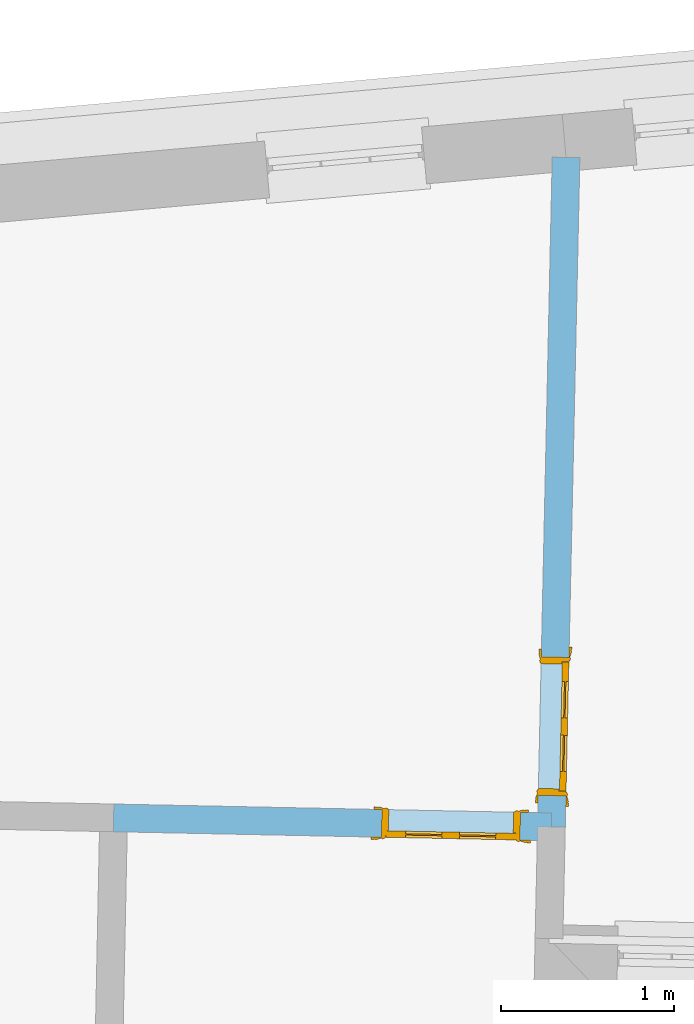
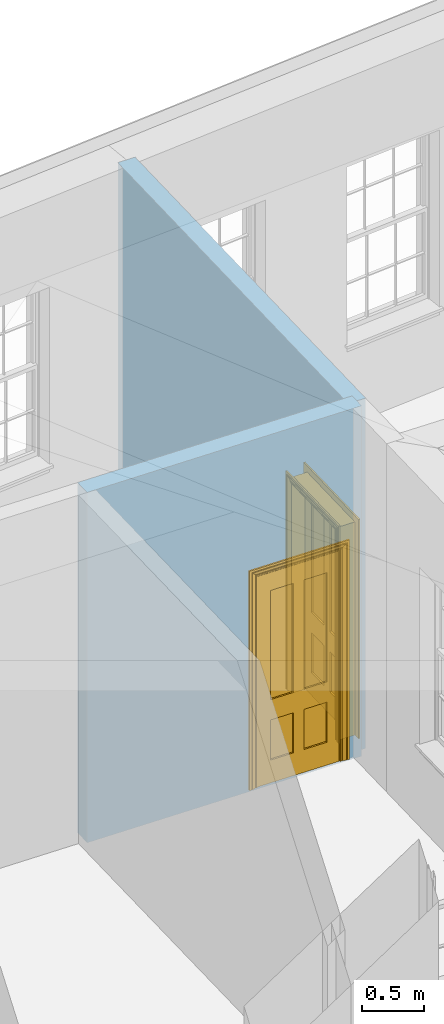
# One storey, part 10 of 14: 2 doors, 2 openings, plus 2 elements that do not belong to this part.
"""IFC2X3 building model written with IfcOpenShell, lengths in metres."""

import ifcopenshell
import ifcopenshell.guid

model = None  # the IFC model being written
_history = None  # IfcOwnerHistory: only IFC2X3 demands one
_inside = {}  # id of a spatial element -> (the spatial element, [elements in it])
_under = {}  # id of a project, library or spatial element -> (it, [spatial elements below it])
_declared = {}  # id of a project -> (the project, [libraries it declares])
_typed = {}  # id of a type object -> (the type object, [elements of that type])
_made_of = {}  # id of a material, layer set ... -> (it, [elements and type objects made of it])


def new_model(schema):
    """Start an empty IFC model of exactly this schema.

    Asked for "IFC4X3", IfcOpenShell would pick the latest addendum, in which some entities
    have other attributes; the version numbers below select the first issue.
    IFC2X3 requires an IfcOwnerHistory on every rooted entity: one is made here for all.
    """
    global model, _history
    if schema == "IFC4X3":
        model = ifcopenshell.file(schema_version=(4, 3, 0, 0))
    else:
        model = ifcopenshell.file(schema=schema)
    _inside.clear()
    _under.clear()
    _declared.clear()
    _typed.clear()
    _made_of.clear()
    _history = None
    if model.schema == "IFC2X3":
        org = make("IfcOrganization", Name="unknown")
        user = make(
            "IfcPersonAndOrganization",
            ThePerson=make("IfcPerson", FamilyName="unknown"),
            TheOrganization=org,
        )
        app = make(
            "IfcApplication",
            ApplicationDeveloper=org,
            Version="unknown",
            ApplicationFullName="unknown",
            ApplicationIdentifier="unknown",
        )
        _history = make(
            "IfcOwnerHistory",
            OwningUser=user,
            OwningApplication=app,
            ChangeAction="ADDED",
            CreationDate=0,
        )
    return model


def make(cls, **values):
    """One entity of the class cls with the attributes given. An attribute that is None is left unset."""
    return model.create_entity(
        cls, **{name: value for name, value in values.items() if value is not None}
    )


def rooted(cls, **values):
    """An entity with a GlobalId (a new one), such as an element, a storey or a relation."""
    return make(cls, GlobalId=ifcopenshell.guid.new(), OwnerHistory=_history, **values)


def si_unit(unit_type, name, prefix=None):
    """IfcSIUnit, for example si_unit("LENGTHUNIT", "METRE", prefix="MILLI")."""
    return make("IfcSIUnit", UnitType=unit_type, Prefix=prefix, Name=name)


def assignment(units):
    """IfcUnitAssignment: the units of a project."""
    return None if units is None else make("IfcUnitAssignment", Units=units)


def point(xyz):
    """IfcCartesianPoint."""
    return None if xyz is None else make("IfcCartesianPoint", Coordinates=xyz)


def direction(xyz):
    """IfcDirection."""
    return None if xyz is None else make("IfcDirection", DirectionRatios=xyz)


def frame(location, z_axis=None, x_axis=None):
    """IfcAxis2Placement3D, a coordinate frame: its origin and axes. An axis left out is left unset."""
    return make(
        "IfcAxis2Placement3D",
        Location=point(location),
        Axis=direction(z_axis),
        RefDirection=direction(x_axis),
    )


def origin():
    """The frame at (0, 0, 0) with its axes left unset."""
    return frame((0.0, 0.0, 0.0))


def place(relative_to, where):
    """IfcLocalPlacement: puts the frame where relative to a parent placement (None: the world)."""
    return make(
        "IfcLocalPlacement", PlacementRelTo=relative_to, RelativePlacement=where
    )


def context(
    kind, dimensions, precision=None, world=None, true_north=None, identifier=None
):
    """IfcGeometricRepresentationContext, for example the 3D "Model" context."""
    return make(
        "IfcGeometricRepresentationContext",
        ContextIdentifier=identifier,
        ContextType=kind,
        CoordinateSpaceDimension=dimensions,
        Precision=precision,
        WorldCoordinateSystem=world,
        TrueNorth=true_north,
    )


def subcontext(parent, identifier, kind, view, scale=None):
    """IfcGeometricRepresentationSubContext, for example "Body" below "Model"."""
    return make(
        "IfcGeometricRepresentationSubContext",
        ContextIdentifier=identifier,
        ContextType=kind,
        ParentContext=parent,
        TargetScale=scale,
        TargetView=view,
    )


def project(units=None, contexts=None):
    """IfcProject with its units and contexts."""
    return rooted(
        "IfcProject",
        Name="project",
        RepresentationContexts=contexts,
        UnitsInContext=assignment(units),
    )


def spatial(cls, under=None, at=None, **own):
    """A site, building, storey or space (cls), placed at a placement, below another one or the project."""
    s = rooted(cls, ObjectPlacement=at, **own)
    if under is not None:
        _under.setdefault(under.id(), (under, []))[1].append(s)
    return s


def polyline(points):
    """IfcPolyline through the points."""
    return make("IfcPolyline", Points=[point(p) for p in points])


def outline(outer, holes=None, kind="AREA"):
    """IfcArbitraryClosedProfileDef: a profile drawn as a closed curve; with holes, ...WithVoids."""
    if holes is None:
        return make("IfcArbitraryClosedProfileDef", ProfileType=kind, OuterCurve=outer)
    return make(
        "IfcArbitraryProfileDefWithVoids",
        ProfileType=kind,
        OuterCurve=outer,
        InnerCurves=holes,
    )


def extrude(swept, where, along, depth):
    """IfcExtrudedAreaSolid: the profile swept, set in the frame where, extruded along a direction by depth."""
    return make(
        "IfcExtrudedAreaSolid",
        SweptArea=swept,
        Position=where,
        ExtrudedDirection=direction(along),
        Depth=depth,
    )


def faces_of(points, faces, orient=None, outer=None):
    """IfcFace entities. A face is a list of loops; a loop is a list of indices into points, from 0.

    orient and outer hold one flag for each loop. By default every Orientation is true, the
    first loop of a face is its IfcFaceOuterBound and the others are IfcFaceBound.
    """
    made = []
    for i, loops in enumerate(faces):
        bounds = []
        for j, loop in enumerate(loops):
            is_outer = j == 0 if outer is None else outer[i][j]
            bounds.append(
                make(
                    "IfcFaceOuterBound" if is_outer else "IfcFaceBound",
                    Bound=make("IfcPolyLoop", Polygon=[points[k] for k in loop]),
                    Orientation=True if orient is None else orient[i][j],
                )
            )
        made.append(make("IfcFace", Bounds=bounds))
    return made


def faceted_brep(points, faces, orient=None, outer=None, voids=None):
    """IfcFacetedBrep: a solid bounded by flat faces; with voids (closed shells), ...WithVoids."""
    shared = [point(p) for p in points]
    hull = make("IfcClosedShell", CfsFaces=faces_of(shared, faces, orient, outer))
    if voids is None:
        return make("IfcFacetedBrep", Outer=hull)
    return make(
        "IfcFacetedBrepWithVoids",
        Outer=hull,
        Voids=[
            make(cls, CfsFaces=faces_of(shared, fs, o, b)) for cls, fs, o, b in voids
        ],
    )


def shape(context_of_items, identifier, shape_type, items):
    """IfcShapeRepresentation: the items that make up one representation, for example the "Body"."""
    return make(
        "IfcShapeRepresentation",
        ContextOfItems=context_of_items,
        RepresentationIdentifier=identifier,
        RepresentationType=shape_type,
        Items=items,
    )


def material(Name=None, Category=None):
    """IfcMaterial."""
    return make("IfcMaterial", Name=Name, Category=Category)


def layer(
    of_material, thickness, ventilated=None, Name=None, Category=None, Priority=None
):
    """IfcMaterialLayer: one layer of a wall or slab, of a material (None: an air gap)."""
    return make(
        "IfcMaterialLayer",
        Material=of_material,
        LayerThickness=thickness,
        IsVentilated=ventilated,
        Name=Name,
        Category=Category,
        Priority=Priority,
    )


def layer_set(layers, Name=None):
    """IfcMaterialLayerSet."""
    return make("IfcMaterialLayerSet", MaterialLayers=layers, LayerSetName=Name)


def layer_usage(for_layer_set, set_direction, sense, offset, extent=None):
    """IfcMaterialLayerSetUsage: how a layer set lies in its element."""
    return make(
        "IfcMaterialLayerSetUsage",
        ForLayerSet=for_layer_set,
        LayerSetDirection=set_direction,
        DirectionSense=sense,
        OffsetFromReferenceLine=offset,
        ReferenceExtent=extent,
    )


def made_of(thing, what):
    """Note that an element or type object is made of a material, layer set ...; save() writes the relation."""
    if what is not None:
        _made_of.setdefault(what.id(), (what, []))[1].append(thing)
    return thing


def element(
    cls,
    number,
    at=None,
    inside=None,
    cuts=None,
    type_object=None,
    material=None,
    context=None,
    identifier="Body",
    shape_type=None,
    held_by="IfcProductDefinitionShape",
    body=None,
    shapes=None,
    **own,
):
    """One element of the class cls, such as IfcWall. Its Tag is "e" and its number.

    at: its placement. inside: the storey or other place that contains it. cuts: it is an
    opening in that element (IfcRelVoidsElement). A single representation is given by context,
    identifier, shape_type and body (its items); several are given by shapes. held_by: the class
    of the entity that holds the representations. save() writes the other relations.
    """
    e = rooted(cls, Tag="e%d" % number, ObjectPlacement=at, **own)
    if body is not None:
        shapes = [shape(context, identifier, shape_type, body)]
    if shapes is not None:
        e.Representation = make(held_by, Representations=shapes)
    if inside is not None:
        _inside.setdefault(inside.id(), (inside, []))[1].append(e)
    if cuts is not None:
        rooted(
            "IfcRelVoidsElement", RelatingBuildingElement=cuts, RelatedOpeningElement=e
        )
    if type_object is not None:
        _typed.setdefault(type_object.id(), (type_object, []))[1].append(e)
    return made_of(e, material)


def fill(opening, filler):
    """IfcRelFillsElement: the door or window that sits in an opening."""
    return rooted(
        "IfcRelFillsElement",
        RelatingOpeningElement=opening,
        RelatedBuildingElement=filler,
    )


def aggregate(whole, parts):
    """IfcRelAggregates: a whole, such as a stair, and the parts it consists of."""
    return rooted("IfcRelAggregates", RelatingObject=whole, RelatedObjects=parts)


def save(model, path):
    """Write the relations noted so far, then the file.

    IfcRelAggregates (storeys below a building ...), IfcRelContainedInSpatialStructure (elements
    in a storey), IfcRelDefinesByType, IfcRelAssociatesMaterial and IfcRelDeclares: one each for
    every whole, place, type object, material and project.
    """
    for whole, parts in _under.values():
        aggregate(whole, parts)
    for where, things in _inside.values():
        rooted(
            "IfcRelContainedInSpatialStructure",
            RelatedElements=things,
            RelatingStructure=where,
        )
    for kind, things in _typed.values():
        rooted("IfcRelDefinesByType", RelatedObjects=things, RelatingType=kind)
    for what, things in _made_of.values():
        rooted("IfcRelAssociatesMaterial", RelatedObjects=things, RelatingMaterial=what)
    for by, libraries in _declared.values():
        rooted("IfcRelDeclares", RelatingContext=by, RelatedDefinitions=libraries)
    model.write(path)


model = new_model("IFC2X3")

# Units and contexts
model_context = context("Model", 3, world=origin())
body_context = subcontext(model_context, "Body", "Model", "MODEL_VIEW")
ifc_project = project(units=[si_unit("PLANEANGLEUNIT", "RADIAN"), si_unit("MASSUNIT", "GRAM", prefix="KILO"), si_unit("FORCEUNIT", "NEWTON", prefix="KILO"), si_unit("LENGTHUNIT", "METRE")], contexts=[model_context])

# Site, building, storey
site_placement = place(None, origin())
site = spatial("IfcSite", under=ifc_project, at=site_placement, CompositionType="ELEMENT")
building_placement = place(None, origin())
building = spatial("IfcBuilding", under=site, at=building_placement, Name="Building plot-17", CompositionType="ELEMENT")
storey_placement = place(None, frame((0.0, 0.0, 6.15)))
storey = spatial("IfcBuildingStorey", under=building, at=storey_placement, Name="Floor 1", CompositionType="ELEMENT", Elevation=6.15)

# Wall, opening, door
ifc_material = material(Name="Masonry")
ifc_layer = layer(ifc_material, 0.16, ventilated=False)
ifc_layer_set = layer_set([ifc_layer], Name="My Wall")
ifc_layer_usage = layer_usage(ifc_layer_set, "AXIS2", "NEGATIVE", 0.08)
wall_1_placement = place(storey_placement, origin())
wall_1 = element("IfcWallStandardCase", 1, at=wall_1_placement, inside=storey, material=ifc_layer_usage, Name="interior", context=body_context, shape_type="SweptSolid", body=[
    extrude(outline(polyline([(82.5849794161083, 26.5932302615352), (82.4250176741949, 26.596728993307), (82.3405092270944, 22.7330094267186), (82.5004709690078, 22.7295106949468), (82.5849794161083, 26.5932302615352)])), origin(), (0.0, 0.0, 1.0), 3.45),
])
opening_1_placement = place(storey_placement, frame((0.0, 0.0, 0.0199999999999996)))
opening_1 = element("IfcOpeningElement", 2, at=opening_1_placement, cuts=wall_1, Name="Opening", ObjectType="Opening", context=body_context, shape_type="SweptSolid", body=[
    extrude(outline(polyline([(82.3619389591961, 23.7127750959385), (82.3444453003375, 22.9129663863712), (82.504407042251, 22.9094676545995), (82.5219007011096, 23.7092763641668), (82.3619389591961, 23.7127750959385)])), origin(), (0.0, 0.0, 1.0), 2.1),
])
door_1_placement = place(storey_placement, frame((82.4419198301528, 23.7110257300527, 0.0199999999999996), z_axis=(0.0, 0.0, 1.0), x_axis=(-0.0174936588585552, -0.799808709567319, 0.0)))
door_1 = element("IfcDoor", 3, at=door_1_placement, inside=storey, Name="bedroom inside door", OverallHeight=2.1, OverallWidth=0.8, context=body_context, shape_type="Brep", held_by="IfcProductRepresentation", body=[
    faceted_brep([(0.773, 0.08, 1.895), (0.66, 0.08, 1.895), (0.66, 0.08, 2.073), (0.773, 0.08, 2.073), (0.773, 0.08, 0.82), (0.66, 0.08, 0.82), (0.45, 0.08, 1.895), (0.45, 0.08, 2.073), (0.773, 0.08, 0.62), (0.66, 0.08, 0.62), (0.66, 0.065, 0.82), (0.66, 0.065, 1.895), (0.45, 0.065, 1.895), (0.35, 0.08, 1.895), (0.35, 0.08, 2.073), (0.773, 0.08, 0.225), (0.66, 0.08, 0.225), (0.45, 0.08, 0.62), (0.45, 0.08, 0.82), (0.45, 0.065, 0.82), (0.35, 0.08, 0.82), (0.14, 0.08, 2.073), (0.14, 0.08, 1.895), (0.773, 0.08, 0.0), (0.66, 0.08, 0.0), (0.66, 0.065, 0.225), (0.66, 0.065, 0.62), (0.45, 0.065, 0.62), (0.35, 0.08, 0.62), (0.35, 0.065, 0.82), (0.35, 0.065, 1.895), (0.14, 0.065, 1.895), (0.027, 0.08, 2.073), (0.027, 0.08, 1.895), (0.773, 0.042, 0.0), (0.66, 0.042, 0.0), (0.45, 0.08, 0.0), (0.45, 0.08, 0.225), (0.45, 0.065, 0.225), (0.35, 0.08, 0.225), (0.14, 0.08, 0.82), (0.14, 0.08, 0.62), (0.14, 0.065, 0.82), (0.027, 0.08, 0.82), (0.773, 0.042, 0.225), (0.66, 0.042, 0.225), (0.45, 0.042, 0.0), (0.35, 0.08, 0.0), (0.35, 0.065, 0.225), (0.35, 0.065, 0.62), (0.14, 0.065, 0.62), (0.027, 0.08, 0.62), (0.773, 0.042, 0.62), (0.66, 0.042, 0.62), (0.45, 0.042, 0.225), (0.35, 0.042, 0.0), (0.14, 0.08, 0.225), (0.14, 0.08, 0.0), (0.14, 0.065, 0.225), (0.027, 0.08, 0.225), (0.773, 0.042, 0.82), (0.66, 0.042, 0.82), (0.66, 0.057, 0.62), (0.66, 0.057, 0.225), (0.45, 0.057, 0.225), (0.35, 0.042, 0.225), (0.14, 0.042, 0.0), (0.027, 0.08, 0.0), (0.773, 0.042, 1.895), (0.66, 0.042, 1.895), (0.45, 0.042, 0.62), (0.45, 0.042, 0.82), (0.45, 0.057, 0.62), (0.35, 0.042, 0.62), (0.14, 0.042, 0.225), (0.027, 0.042, 0.0), (0.773, 0.042, 2.073), (0.66, 0.042, 2.073), (0.66, 0.057, 1.895), (0.66, 0.057, 0.82), (0.45, 0.057, 0.82), (0.35, 0.042, 0.82), (0.35, 0.057, 0.62), (0.35, 0.057, 0.225), (0.14, 0.057, 0.225), (0.027, 0.042, 0.225), (0.45, 0.042, 1.895), (0.45, 0.042, 2.073), (0.45, 0.057, 1.895), (0.35, 0.042, 1.895), (0.14, 0.042, 0.82), (0.14, 0.042, 0.62), (0.14, 0.057, 0.62), (0.027, 0.042, 0.62), (0.35, 0.042, 2.073), (0.35, 0.057, 1.895), (0.35, 0.057, 0.82), (0.14, 0.057, 0.82), (0.027, 0.042, 0.82), (0.14, 0.042, 2.073), (0.14, 0.042, 1.895), (0.14, 0.057, 1.895), (0.027, 0.042, 1.895), (0.027, 0.042, 2.073), (0.02, 0.085, 0.0), (0.005, 0.09, 0.0), (0.005, 0.09, 2.095), (0.02, 0.085, 2.08), (0.02, 0.08, 0.0), (0.0, 0.085, 0.0), (0.0, 0.085, 2.1), (0.795, 0.09, 2.095), (0.78, 0.085, 2.08), (0.02, 0.08, 2.08), (0.0, 0.08, 0.0), (-0.032, 0.095, 0.0), (-0.032, 0.095, 2.132), (0.8, 0.085, 2.1), (0.795, 0.09, 0.0), (0.78, 0.085, 0.0), (0.78, 0.08, 2.08), (0.04, 0.04, 0.0), (0.025, 0.04, 0.0), (0.025, 0.04, 2.075), (0.04, 0.04, 2.06), (-0.04, 0.09, 0.0), (-0.04, 0.09, 2.14), (0.832, 0.095, 2.132), (0.8, 0.085, 0.0), (0.78, 0.08, 0.0), (0.8, 0.08, 0.0), (0.86, 0.08, 0.0), (0.86, 0.08, 2.16), (0.8, 0.08, 2.1), (-0.06, 0.08, 2.16), (0.0, 0.08, 2.1), (-0.06, 0.08, 0.0), (-0.04, 0.095, 0.0), (-0.04, 0.095, 2.14), (0.84, 0.09, 2.14), (0.832, 0.095, 0.0), (0.84, 0.09, 0.0), (0.86, 0.095, 0.0), (0.86, 0.095, 2.16), (-0.06, 0.095, 2.16), (-0.06, 0.095, 0.0), (0.84, 0.095, 0.0), (0.84, 0.095, 2.14), (-0.025, -0.095, 0.0), (-0.025, -0.09, 0.0), (-0.025, -0.09, 2.125), (-0.025, -0.095, 2.125), (-0.017, -0.095, 0.0), (-0.017, -0.095, 2.117), (0.825, -0.09, 2.125), (0.825, -0.095, 2.125), (0.825, -0.095, 0.0), (0.845, -0.095, 0.0), (-0.045, -0.095, 2.145), (-0.045, -0.095, 0.0), (0.845, -0.095, 2.145), (0.015, -0.085, 0.0), (0.015, -0.085, 2.085), (0.817, -0.095, 2.117), (0.825, -0.09, 0.0), (0.845, -0.08, 0.0), (0.845, -0.08, 2.145), (-0.045, -0.08, 2.145), (-0.045, -0.08, 0.0), (0.02, -0.09, 0.0), (0.02, -0.09, 2.08), (0.785, -0.085, 2.085), (0.817, -0.095, 0.0), (0.8, -0.08, 0.0), (0.8, -0.08, 2.1), (0.0, -0.08, 2.1), (0.0, -0.08, 0.0), (0.035, -0.085, 0.0), (0.035, -0.085, 2.065), (0.78, -0.09, 2.08), (0.785, -0.085, 0.0), (0.775, 0.04, 2.075), (0.76, 0.04, 2.06), (0.035, -0.08, 2.065), (0.035, -0.08, 0.0), (0.765, -0.085, 2.065), (0.78, -0.09, 0.0), (0.765, -0.08, 0.0), (0.765, -0.08, 2.065), (0.765, -0.085, 0.0), (0.04, -0.08, 2.06), (0.04, -0.08, 0.0), (0.76, -0.08, 2.06), (0.76, -0.08, 0.0), (0.76, 0.04, 0.0), (0.775, 0.04, 0.0), (0.025, 0.08, 0.0), (0.025, 0.08, 2.075), (0.775, 0.08, 0.0), (0.775, 0.08, 2.075)], [[[0, 1, 2, 3]], [[1, 0, 4, 5]], [[1, 6, 7, 2]], [[8, 9, 5, 4]], [[1, 5, 10, 11]], [[6, 1, 11, 12]], [[6, 13, 14, 7]], [[15, 16, 9, 8]], [[9, 17, 18, 5]], [[5, 18, 19, 10]], [[10, 19, 12, 11]], [[18, 6, 12, 19]], [[18, 20, 13, 6]], [[21, 14, 13, 22]], [[23, 24, 16, 15]], [[9, 16, 25, 26]], [[17, 9, 26, 27]], [[17, 28, 20, 18]], [[13, 20, 29, 30]], [[22, 13, 30, 31]], [[32, 21, 22, 33]], [[34, 35, 24, 23]], [[24, 36, 37, 16]], [[16, 37, 38, 25]], [[25, 38, 27, 26]], [[37, 17, 27, 38]], [[37, 39, 28, 17]], [[40, 20, 28, 41]], [[20, 40, 42, 29]], [[31, 30, 29, 42]], [[40, 22, 31, 42]], [[33, 22, 40, 43]], [[35, 34, 44, 45]], [[35, 46, 36, 24]], [[36, 47, 39, 37]], [[28, 39, 48, 49]], [[41, 28, 49, 50]], [[43, 40, 41, 51]], [[45, 44, 52, 53]], [[46, 35, 45, 54]], [[46, 55, 47, 36]], [[56, 39, 47, 57]], [[39, 56, 58, 48]], [[50, 49, 48, 58]], [[56, 41, 50, 58]], [[51, 41, 56, 59]], [[53, 52, 60, 61]], [[45, 53, 62, 63]], [[54, 45, 63, 64]], [[55, 46, 54, 65]], [[55, 66, 57, 47]], [[59, 56, 57, 67]], [[61, 60, 68, 69]], [[70, 53, 61, 71]], [[53, 70, 72, 62]], [[72, 64, 63, 62]], [[70, 54, 64, 72]], [[65, 54, 70, 73]], [[65, 74, 66, 55]], [[67, 57, 66, 75]], [[69, 68, 76, 77]], [[61, 69, 78, 79]], [[71, 61, 79, 80]], [[73, 70, 71, 81]], [[65, 73, 82, 83]], [[74, 65, 83, 84]], [[74, 85, 75, 66]], [[86, 69, 77, 87]], [[69, 86, 88, 78]], [[88, 80, 79, 78]], [[86, 71, 80, 88]], [[81, 71, 86, 89]], [[73, 81, 90, 91]], [[73, 91, 92, 82]], [[83, 82, 92, 84]], [[91, 74, 84, 92]], [[91, 93, 85, 74]], [[89, 86, 87, 94]], [[81, 89, 95, 96]], [[90, 81, 96, 97]], [[90, 98, 93, 91]], [[94, 99, 100, 89]], [[89, 100, 101, 95]], [[101, 97, 96, 95]], [[100, 90, 97, 101]], [[100, 102, 98, 90]], [[99, 103, 102, 100]], [[32, 103, 99, 21]], [[102, 103, 32, 33]], [[98, 102, 33, 43]], [[21, 99, 94, 14]], [[94, 87, 7, 14]], [[7, 87, 77, 2]], [[76, 3, 2, 77]], [[43, 51, 93, 98]], [[51, 59, 85, 93]], [[67, 75, 85, 59]], [[34, 23, 15, 44]], [[44, 15, 8, 52]], [[52, 8, 4, 60]], [[0, 68, 60, 4]], [[0, 3, 76, 68]], [[104, 105, 106, 107]], [[104, 108, 109, 105]], [[105, 109, 110, 106]], [[107, 106, 111, 112]], [[107, 113, 108, 104]], [[114, 109, 108]], [[109, 115, 116, 110]], [[106, 110, 117, 111]], [[112, 111, 118, 119]], [[113, 107, 112, 120]], [[121, 122, 123, 124]], [[115, 109, 114, 125]], [[115, 125, 126, 116]], [[110, 116, 127, 117]], [[111, 117, 128, 118]], [[118, 128, 129, 119]], [[120, 112, 119, 129]], [[130, 129, 128]], [[130, 131, 132, 133]], [[133, 132, 134, 135]], [[135, 134, 136, 114]], [[136, 125, 114]], [[125, 137, 138, 126]], [[116, 126, 139, 127]], [[117, 127, 140, 128]], [[141, 130, 128, 140]], [[131, 130, 141]], [[131, 142, 143, 132]], [[132, 143, 144, 134]], [[134, 144, 145, 136]], [[137, 125, 136, 145]], [[143, 142, 146]], [[143, 146, 147]], [[137, 145, 144]], [[143, 147, 138]], [[138, 137, 144]], [[143, 138, 144]], [[126, 138, 147, 139]], [[127, 139, 141, 140]], [[142, 131, 141, 146]], [[139, 147, 146, 141]], [[148, 149, 150, 151]], [[149, 152, 153, 150]], [[151, 150, 154, 155]], [[155, 156, 157]], [[158, 159, 148]], [[158, 148, 151]], [[155, 157, 160]], [[158, 151, 155]], [[155, 160, 158]], [[152, 161, 162, 153]], [[150, 153, 163, 154]], [[155, 154, 164, 156]], [[156, 164, 165, 157]], [[157, 165, 166, 160]], [[160, 166, 167, 158]], [[158, 167, 168, 159]], [[161, 169, 170, 162]], [[153, 162, 171, 163]], [[154, 163, 172, 164]], [[165, 164, 173]], [[165, 173, 174, 166]], [[166, 174, 175, 167]], [[167, 175, 176, 168]], [[169, 177, 178, 170]], [[162, 170, 179, 171]], [[163, 171, 180, 172]], [[172, 180, 173, 164]], [[124, 123, 181, 182]], [[183, 178, 177, 184]], [[170, 178, 185, 179]], [[171, 179, 186, 180]], [[187, 173, 180]], [[185, 188, 187, 189]], [[188, 185, 178, 183]], [[179, 185, 189, 186]], [[189, 187, 180, 186]], [[190, 183, 184, 191]], [[192, 188, 183, 190]], [[191, 184, 122, 121]], [[124, 190, 191, 121]], [[193, 187, 188, 192]], [[182, 192, 190, 124]], [[184, 176, 122]], [[194, 195, 187, 193]], [[192, 182, 194, 193]], [[161, 176, 184]], [[114, 108, 122, 176]], [[173, 187, 195]], [[152, 149, 176, 161]], [[169, 161, 184, 177]], [[196, 122, 108]], [[176, 175, 135, 114]], [[173, 195, 129, 130]], [[176, 149, 168]], [[123, 122, 196, 197]], [[196, 108, 113, 197]], [[175, 174, 133, 135]], [[198, 129, 195]], [[133, 174, 173, 130]], [[159, 168, 149, 148]], [[181, 123, 197, 199]], [[197, 113, 120, 199]], [[199, 120, 129, 198]], [[195, 181, 199, 198]], [[195, 194, 182, 181]]]),
])
fill(opening_1, door_1)

wall_2_placement = place(storey_placement, origin())
wall_2 = element("IfcWallStandardCase", 4, at=wall_2_placement, inside=storey, material=ifc_layer_usage, Name="interior", context=body_context, shape_type="SweptSolid", body=[
    extrude(outline(polyline([(82.4188572551841, 22.6512767261675), (82.4221229409181, 22.8112433954979), (79.8950312686758, 22.8628334377044), (79.8917655829418, 22.702866768374), (82.4188572551841, 22.6512767261675)])), origin(), (0.0, 0.0, 1.0), 3.45),
])
opening_2_placement = place(storey_placement, frame((0.0, 0.0, 0.0199999999999996)))
opening_2 = element("IfcOpeningElement", 5, at=opening_2_placement, cuts=wall_2, Name="Opening", ObjectType="Opening", context=body_context, shape_type="SweptSolid", body=[
    extrude(outline(polyline([(82.2421604379213, 22.8149172919486), (81.4423270912689, 22.8312457206183), (81.4390614055349, 22.6712790512878), (82.2388947521873, 22.6549506226181), (82.2421604379213, 22.8149172919486)])), origin(), (0.0, 0.0, 1.0), 2.1),
])
door_2_placement = place(storey_placement, frame((82.2405275950543, 22.7349339572834, 0.0199999999999996), z_axis=(0.0, 0.0, 1.0), x_axis=(-0.799833346652406, 0.0163284286696843, 0.0)))
door_2 = element("IfcDoor", 6, at=door_2_placement, inside=storey, Name="toilet inside door", OverallHeight=2.1, OverallWidth=0.8, context=body_context, shape_type="Brep", held_by="IfcProductRepresentation", body=[
    faceted_brep([(0.773, 0.08, 1.895), (0.66, 0.08, 1.895), (0.66, 0.08, 2.073), (0.773, 0.08, 2.073), (0.773, 0.08, 0.82), (0.66, 0.08, 0.82), (0.45, 0.08, 1.895), (0.45, 0.08, 2.073), (0.773, 0.08, 0.62), (0.66, 0.08, 0.62), (0.66, 0.065, 0.82), (0.66, 0.065, 1.895), (0.45, 0.065, 1.895), (0.35, 0.08, 1.895), (0.35, 0.08, 2.073), (0.773, 0.08, 0.225), (0.66, 0.08, 0.225), (0.45, 0.08, 0.62), (0.45, 0.08, 0.82), (0.45, 0.065, 0.82), (0.35, 0.08, 0.82), (0.14, 0.08, 2.073), (0.14, 0.08, 1.895), (0.773, 0.08, 0.0), (0.66, 0.08, 0.0), (0.66, 0.065, 0.225), (0.66, 0.065, 0.62), (0.45, 0.065, 0.62), (0.35, 0.08, 0.62), (0.35, 0.065, 0.82), (0.35, 0.065, 1.895), (0.14, 0.065, 1.895), (0.027, 0.08, 2.073), (0.027, 0.08, 1.895), (0.773, 0.042, 0.0), (0.66, 0.042, 0.0), (0.45, 0.08, 0.0), (0.45, 0.08, 0.225), (0.45, 0.065, 0.225), (0.35, 0.08, 0.225), (0.14, 0.08, 0.82), (0.14, 0.08, 0.62), (0.14, 0.065, 0.82), (0.027, 0.08, 0.82), (0.773, 0.042, 0.225), (0.66, 0.042, 0.225), (0.45, 0.042, 0.0), (0.35, 0.08, 0.0), (0.35, 0.065, 0.225), (0.35, 0.065, 0.62), (0.14, 0.065, 0.62), (0.027, 0.08, 0.62), (0.773, 0.042, 0.62), (0.66, 0.042, 0.62), (0.45, 0.042, 0.225), (0.35, 0.042, 0.0), (0.14, 0.08, 0.225), (0.14, 0.08, 0.0), (0.14, 0.065, 0.225), (0.027, 0.08, 0.225), (0.773, 0.042, 0.82), (0.66, 0.042, 0.82), (0.66, 0.057, 0.62), (0.66, 0.057, 0.225), (0.45, 0.057, 0.225), (0.35, 0.042, 0.225), (0.14, 0.042, 0.0), (0.027, 0.08, 0.0), (0.773, 0.042, 1.895), (0.66, 0.042, 1.895), (0.45, 0.042, 0.62), (0.45, 0.042, 0.82), (0.45, 0.057, 0.62), (0.35, 0.042, 0.62), (0.14, 0.042, 0.225), (0.027, 0.042, 0.0), (0.773, 0.042, 2.073), (0.66, 0.042, 2.073), (0.66, 0.057, 1.895), (0.66, 0.057, 0.82), (0.45, 0.057, 0.82), (0.35, 0.042, 0.82), (0.35, 0.057, 0.62), (0.35, 0.057, 0.225), (0.14, 0.057, 0.225), (0.027, 0.042, 0.225), (0.45, 0.042, 1.895), (0.45, 0.042, 2.073), (0.45, 0.057, 1.895), (0.35, 0.042, 1.895), (0.14, 0.042, 0.82), (0.14, 0.042, 0.62), (0.14, 0.057, 0.62), (0.027, 0.042, 0.62), (0.35, 0.042, 2.073), (0.35, 0.057, 1.895), (0.35, 0.057, 0.82), (0.14, 0.057, 0.82), (0.027, 0.042, 0.82), (0.14, 0.042, 2.073), (0.14, 0.042, 1.895), (0.14, 0.057, 1.895), (0.027, 0.042, 1.895), (0.027, 0.042, 2.073), (0.02, 0.085, 0.0), (0.005, 0.09, 0.0), (0.005, 0.09, 2.095), (0.02, 0.085, 2.08), (0.02, 0.08, 0.0), (0.0, 0.085, 0.0), (0.0, 0.085, 2.1), (0.795, 0.09, 2.095), (0.78, 0.085, 2.08), (0.02, 0.08, 2.08), (0.0, 0.08, 0.0), (-0.032, 0.095, 0.0), (-0.032, 0.095, 2.132), (0.8, 0.085, 2.1), (0.795, 0.09, 0.0), (0.78, 0.085, 0.0), (0.78, 0.08, 2.08), (0.04, 0.04, 0.0), (0.025, 0.04, 0.0), (0.025, 0.04, 2.075), (0.04, 0.04, 2.06), (-0.04, 0.09, 0.0), (-0.04, 0.09, 2.14), (0.832, 0.095, 2.132), (0.8, 0.085, 0.0), (0.78, 0.08, 0.0), (0.8, 0.08, 0.0), (0.86, 0.08, 0.0), (0.86, 0.08, 2.16), (0.8, 0.08, 2.1), (-0.06, 0.08, 2.16), (0.0, 0.08, 2.1), (-0.06, 0.08, 0.0), (-0.04, 0.095, 0.0), (-0.04, 0.095, 2.14), (0.84, 0.09, 2.14), (0.832, 0.095, 0.0), (0.84, 0.09, 0.0), (0.86, 0.095, 0.0), (0.86, 0.095, 2.16), (-0.06, 0.095, 2.16), (-0.06, 0.095, 0.0), (0.84, 0.095, 0.0), (0.84, 0.095, 2.14), (-0.025, -0.095, 0.0), (-0.025, -0.09, 0.0), (-0.025, -0.09, 2.125), (-0.025, -0.095, 2.125), (-0.017, -0.095, 0.0), (-0.017, -0.095, 2.117), (0.825, -0.09, 2.125), (0.825, -0.095, 2.125), (0.825, -0.095, 0.0), (0.845, -0.095, 0.0), (-0.045, -0.095, 2.145), (-0.045, -0.095, 0.0), (0.845, -0.095, 2.145), (0.015, -0.085, 0.0), (0.015, -0.085, 2.085), (0.817, -0.095, 2.117), (0.825, -0.09, 0.0), (0.845, -0.08, 0.0), (0.845, -0.08, 2.145), (-0.045, -0.08, 2.145), (-0.045, -0.08, 0.0), (0.02, -0.09, 0.0), (0.02, -0.09, 2.08), (0.785, -0.085, 2.085), (0.817, -0.095, 0.0), (0.8, -0.08, 0.0), (0.8, -0.08, 2.1), (0.0, -0.08, 2.1), (0.0, -0.08, 0.0), (0.035, -0.085, 0.0), (0.035, -0.085, 2.065), (0.78, -0.09, 2.08), (0.785, -0.085, 0.0), (0.775, 0.04, 2.075), (0.76, 0.04, 2.06), (0.035, -0.08, 2.065), (0.035, -0.08, 0.0), (0.765, -0.085, 2.065), (0.78, -0.09, 0.0), (0.765, -0.08, 0.0), (0.765, -0.08, 2.065), (0.765, -0.085, 0.0), (0.04, -0.08, 2.06), (0.04, -0.08, 0.0), (0.76, -0.08, 2.06), (0.76, -0.08, 0.0), (0.76, 0.04, 0.0), (0.775, 0.04, 0.0), (0.025, 0.08, 0.0), (0.025, 0.08, 2.075), (0.775, 0.08, 0.0), (0.775, 0.08, 2.075)], [[[0, 1, 2, 3]], [[1, 0, 4, 5]], [[1, 6, 7, 2]], [[8, 9, 5, 4]], [[1, 5, 10, 11]], [[6, 1, 11, 12]], [[6, 13, 14, 7]], [[15, 16, 9, 8]], [[9, 17, 18, 5]], [[5, 18, 19, 10]], [[10, 19, 12, 11]], [[18, 6, 12, 19]], [[18, 20, 13, 6]], [[21, 14, 13, 22]], [[23, 24, 16, 15]], [[9, 16, 25, 26]], [[17, 9, 26, 27]], [[17, 28, 20, 18]], [[13, 20, 29, 30]], [[22, 13, 30, 31]], [[32, 21, 22, 33]], [[34, 35, 24, 23]], [[24, 36, 37, 16]], [[16, 37, 38, 25]], [[25, 38, 27, 26]], [[37, 17, 27, 38]], [[37, 39, 28, 17]], [[40, 20, 28, 41]], [[20, 40, 42, 29]], [[31, 30, 29, 42]], [[40, 22, 31, 42]], [[33, 22, 40, 43]], [[35, 34, 44, 45]], [[35, 46, 36, 24]], [[36, 47, 39, 37]], [[28, 39, 48, 49]], [[41, 28, 49, 50]], [[43, 40, 41, 51]], [[45, 44, 52, 53]], [[46, 35, 45, 54]], [[46, 55, 47, 36]], [[56, 39, 47, 57]], [[39, 56, 58, 48]], [[50, 49, 48, 58]], [[56, 41, 50, 58]], [[51, 41, 56, 59]], [[53, 52, 60, 61]], [[45, 53, 62, 63]], [[54, 45, 63, 64]], [[55, 46, 54, 65]], [[55, 66, 57, 47]], [[59, 56, 57, 67]], [[61, 60, 68, 69]], [[70, 53, 61, 71]], [[53, 70, 72, 62]], [[72, 64, 63, 62]], [[70, 54, 64, 72]], [[65, 54, 70, 73]], [[65, 74, 66, 55]], [[67, 57, 66, 75]], [[69, 68, 76, 77]], [[61, 69, 78, 79]], [[71, 61, 79, 80]], [[73, 70, 71, 81]], [[65, 73, 82, 83]], [[74, 65, 83, 84]], [[74, 85, 75, 66]], [[86, 69, 77, 87]], [[69, 86, 88, 78]], [[88, 80, 79, 78]], [[86, 71, 80, 88]], [[81, 71, 86, 89]], [[73, 81, 90, 91]], [[73, 91, 92, 82]], [[83, 82, 92, 84]], [[91, 74, 84, 92]], [[91, 93, 85, 74]], [[89, 86, 87, 94]], [[81, 89, 95, 96]], [[90, 81, 96, 97]], [[90, 98, 93, 91]], [[94, 99, 100, 89]], [[89, 100, 101, 95]], [[101, 97, 96, 95]], [[100, 90, 97, 101]], [[100, 102, 98, 90]], [[99, 103, 102, 100]], [[32, 103, 99, 21]], [[102, 103, 32, 33]], [[98, 102, 33, 43]], [[21, 99, 94, 14]], [[94, 87, 7, 14]], [[7, 87, 77, 2]], [[76, 3, 2, 77]], [[43, 51, 93, 98]], [[51, 59, 85, 93]], [[67, 75, 85, 59]], [[34, 23, 15, 44]], [[44, 15, 8, 52]], [[52, 8, 4, 60]], [[0, 68, 60, 4]], [[0, 3, 76, 68]], [[104, 105, 106, 107]], [[104, 108, 109, 105]], [[105, 109, 110, 106]], [[107, 106, 111, 112]], [[107, 113, 108, 104]], [[114, 109, 108]], [[109, 115, 116, 110]], [[106, 110, 117, 111]], [[112, 111, 118, 119]], [[113, 107, 112, 120]], [[121, 122, 123, 124]], [[115, 109, 114, 125]], [[115, 125, 126, 116]], [[110, 116, 127, 117]], [[111, 117, 128, 118]], [[118, 128, 129, 119]], [[120, 112, 119, 129]], [[130, 129, 128]], [[130, 131, 132, 133]], [[133, 132, 134, 135]], [[135, 134, 136, 114]], [[136, 125, 114]], [[125, 137, 138, 126]], [[116, 126, 139, 127]], [[117, 127, 140, 128]], [[141, 130, 128, 140]], [[131, 130, 141]], [[131, 142, 143, 132]], [[132, 143, 144, 134]], [[134, 144, 145, 136]], [[137, 125, 136, 145]], [[143, 142, 146]], [[143, 146, 147]], [[137, 145, 144]], [[143, 147, 138]], [[138, 137, 144]], [[143, 138, 144]], [[126, 138, 147, 139]], [[127, 139, 141, 140]], [[142, 131, 141, 146]], [[139, 147, 146, 141]], [[148, 149, 150, 151]], [[149, 152, 153, 150]], [[151, 150, 154, 155]], [[155, 156, 157]], [[158, 159, 148]], [[158, 148, 151]], [[155, 157, 160]], [[158, 151, 155]], [[155, 160, 158]], [[152, 161, 162, 153]], [[150, 153, 163, 154]], [[155, 154, 164, 156]], [[156, 164, 165, 157]], [[157, 165, 166, 160]], [[160, 166, 167, 158]], [[158, 167, 168, 159]], [[161, 169, 170, 162]], [[153, 162, 171, 163]], [[154, 163, 172, 164]], [[165, 164, 173]], [[165, 173, 174, 166]], [[166, 174, 175, 167]], [[167, 175, 176, 168]], [[169, 177, 178, 170]], [[162, 170, 179, 171]], [[163, 171, 180, 172]], [[172, 180, 173, 164]], [[124, 123, 181, 182]], [[183, 178, 177, 184]], [[170, 178, 185, 179]], [[171, 179, 186, 180]], [[187, 173, 180]], [[185, 188, 187, 189]], [[188, 185, 178, 183]], [[179, 185, 189, 186]], [[189, 187, 180, 186]], [[190, 183, 184, 191]], [[192, 188, 183, 190]], [[191, 184, 122, 121]], [[124, 190, 191, 121]], [[193, 187, 188, 192]], [[182, 192, 190, 124]], [[184, 176, 122]], [[194, 195, 187, 193]], [[192, 182, 194, 193]], [[161, 176, 184]], [[114, 108, 122, 176]], [[173, 187, 195]], [[152, 149, 176, 161]], [[169, 161, 184, 177]], [[196, 122, 108]], [[176, 175, 135, 114]], [[173, 195, 129, 130]], [[176, 149, 168]], [[123, 122, 196, 197]], [[196, 108, 113, 197]], [[175, 174, 133, 135]], [[198, 129, 195]], [[133, 174, 173, 130]], [[159, 168, 149, 148]], [[181, 123, 197, 199]], [[197, 113, 120, 199]], [[199, 120, 129, 198]], [[195, 181, 199, 198]], [[195, 194, 182, 181]]]),
])
fill(opening_2, door_2)

save(model, "model.ifc")
